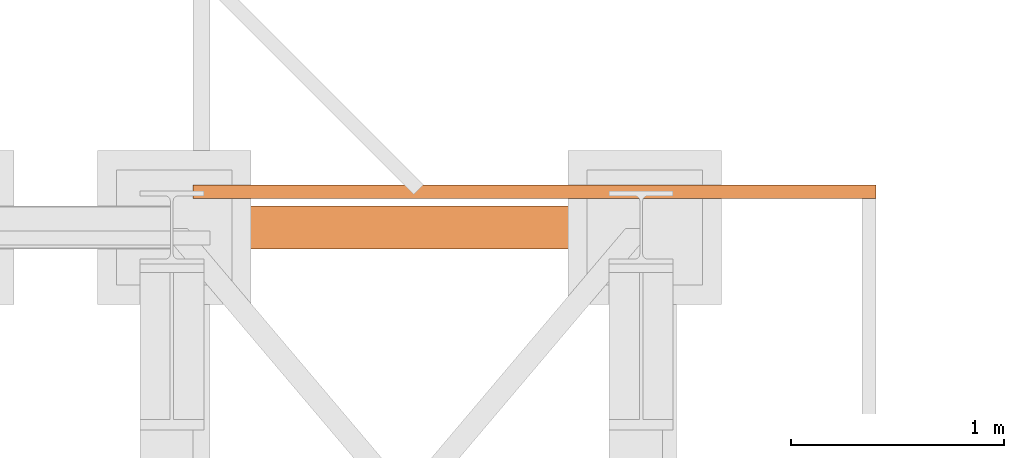
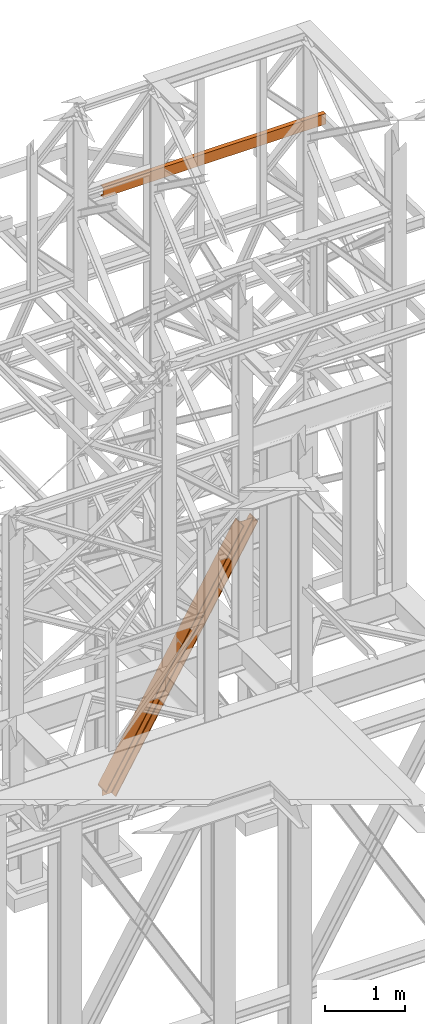
# One storey, part 199 of 208: 2 proxies.
"""IFC2X3 building model written with IfcOpenShell, lengths in millimetres."""

from ifc_helpers import new_model, entity, si_unit, converted_unit, frame, origin, origin_with_axes, place, context, subcontext, project, spatial, faceted_brep, element, save


model = new_model("IFC2X3")

# Units and contexts
model_context = context("Model", 3, precision=1e-05, world=origin())
plan_context = context("Plan", 3, precision=1e-05, world=origin())
body_context = subcontext(model_context, "Body", "Model", "MODEL_VIEW")
ifc_project = project(units=[si_unit("LENGTHUNIT", "METRE", prefix="MILLI"), converted_unit("PLANEANGLEUNIT", "DEGREE", entity("IfcPlaneAngleMeasure", 0.0174532925199433), si_unit("PLANEANGLEUNIT", "RADIAN"), dimensions=[0, 0, 0, 0, 0, 0, 0]), si_unit("AREAUNIT", "SQUARE_METRE"), si_unit("VOLUMEUNIT", "CUBIC_METRE")], contexts=[model_context, plan_context])

# Building, storey
building_placement = place(None, origin())
building = spatial("IfcBuilding", under=ifc_project, at=building_placement, CompositionType="COMPLEX")
storey_placement = place(building_placement, origin_with_axes())
storey = spatial("IfcBuildingStorey", under=building, at=storey_placement, Name="Geschoss", CompositionType="ELEMENT")

# Proxies
proxy_1_placement = place(storey_placement, frame((6599.25488355921, -12562.57439501764, 734.9900149335328), z_axis=(0.0, 0.0, 1.0), x_axis=(1.0, 0.0, 0.0)))
element("IfcBuildingElementProxy", 1, at=proxy_1_placement, inside=storey, context=body_context, shape_type="Brep", body=[
    faceted_brep([(0.01008502161312208, 0.01000000000021828, 120.8497915510924), (0.01008502161312208, 200.0100029802325, 120.8497915510924), (1970.595410063093, 200.0100029802325, 3468.009977913908), (1970.595410063093, 0.01000000000021828, 3468.009977913908), (0.01008502161312208, 200.0100029802325, 120.8497915510924), (0.01008502161312208, 200.0100029802325, 101.4682129393398), (1982.007890767009, 200.0100029802325, 3468.009977913908), (1970.595410063093, 200.0100029802325, 3468.009977913908), (0.01008502161312208, 200.0100029802325, 101.4682129393398), (0.01008502127388056, 121.2600035762789, 101.4681984983711), (1982.007899269971, 121.2600035762789, 3468.009977913908), (1982.007890767009, 200.0100029802325, 3468.009977913908), (0.01008502127388056, 121.2600035762789, 101.4681984983711), (0.009999999999308784, 111.9441915473344, 97.85427409430258), (1984.135808151257, 111.9441915473344, 3468.009977913909), (1982.007899269971, 121.2600035762789, 3468.009977913908), (0.009999999999308784, 111.9441915473344, 97.85427409430258), (0.01008502161312208, 105.1245498640838, 84.63689245399041), (1991.918714280975, 105.1245498640838, 3468.009977913908), (1984.135808151257, 111.9441915473344, 3468.009977913909), (0.01008502161312208, 105.1245498640838, 84.63689245399041), (0.01008502161312208, 103.2600015571716, 66.58142866151923), (2002.550367938204, 103.2600015571716, 3468.009977913908), (1991.918714280975, 105.1245498640838, 3468.009977913908), (0.01008502161312208, 103.2600015571716, 0.009999999999990905), (113.7187158034394, 103.2600015571716, 0.01000000000021828), (2155.477653586077, 103.2600015571716, 3468.009977913908), (2002.550367938204, 103.2600015571716, 3468.009977913908), (0.01008502161312208, 103.2600015571716, 66.58142866151923), (113.7187158034394, 103.2600015571716, 0.01000000000021828), (124.3486060538462, 105.1245498640838, 0.01000000000010459), (2166.109307243305, 105.1245498640838, 3468.009977913908), (2155.477653586077, 103.2600015571716, 3468.009977913908), (124.3486060538462, 105.1245498640838, 0.01000000000010459), (132.1302232850376, 111.9441915473344, 0.009999999999763531), (2173.892213373023, 111.9441915473344, 3468.009977913908), (2166.109307243305, 105.1245498640838, 3468.009977913908), (132.1302232850376, 111.9441915473344, 0.009999999999763531), (134.2577800655363, 121.2600035762789, 0.009999999999763531), (2176.020122254309, 121.2600035762789, 3468.009977913907), (2173.892213373023, 111.9441915473344, 3468.009977913908), (134.2577800655363, 121.2600035762789, 0.009999999999763531), (134.2577800655363, 200.0100029802325, 0.009999999999763531), (2176.020122254309, 200.0100029802325, 3468.009977913907), (2176.020122254309, 121.2600035762789, 3468.009977913907), (134.2577800655363, 200.0100029802325, 0.009999999999763531), (145.6683745225655, 200.0100029802325, 0.009999999999990905), (2187.432602958224, 200.0100029802325, 3468.009977913908), (2176.020122254309, 200.0100029802325, 3468.009977913907), (145.6683745225655, 200.0100029802325, 0.009999999999990905), (145.6683745225655, 0.01000000000021828, 0.009999999999990905), (2187.432602958224, 0.01000000000021828, 3468.009977913908), (2187.432602958224, 200.0100029802325, 3468.009977913908), (145.6683745225655, 0.01000000000021828, 0.009999999999990905), (134.2577800655363, 0.01000000000021828, 0.009999999999877218), (2176.020122254307, 0.01000000000021828, 3468.009977913908), (2187.432602958224, 0.01000000000021828, 3468.009977913908), (134.2577800655363, 0.01000000000021828, 0.009999999999877218), (134.2577800655363, 78.75999940395377, 0.009999999999763531), (2176.020122254309, 78.75999940395377, 3468.009977913907), (2176.020122254307, 0.01000000000021828, 3468.009977913908), (134.2577800655363, 78.75999940395377, 0.009999999999763531), (132.1302232850376, 88.07581143289826, 0.009999999999763531), (2173.892213373023, 88.07581143290008, 3468.009977913908), (2176.020122254309, 78.75999940395377, 3468.009977913907), (132.1302232850376, 88.07581143289826, 0.009999999999763531), (124.3486060538453, 94.89545311614893, 0.009999999999763531), (2166.109307243305, 94.89545311614893, 3468.009977913908), (2173.892213373023, 88.07581143290008, 3468.009977913908), (124.3486060538453, 94.89545311614893, 0.009999999999763531), (113.7187158034394, 96.76000142306111, 0.01000000000021828), (2155.477653586077, 96.76000142306111, 3468.009977913908), (2166.109307243305, 94.89545311614893, 3468.009977913908), (113.7187158034394, 96.76000142306111, 0.01000000000021828), (0.01008502161312208, 96.76000142306111, 0.009999999999990905), (0.01008502161312208, 96.76000142306111, 66.58142866151888), (2002.550367938204, 96.76000142306111, 3468.009977913908), (2155.477653586077, 96.76000142306111, 3468.009977913908), (0.01008502161312208, 96.76000142306111, 66.58142866151888), (0.01008502161312208, 94.89545311615075, 84.63689245399041), (1991.918714280975, 94.89545311614893, 3468.009977913908), (2002.550367938204, 96.76000142306111, 3468.009977913908), (0.01008502161312208, 94.89545311615075, 84.63689245399041), (0.01008502161312208, 88.07581143289826, 97.85441850857092), (1984.135808151257, 88.07581143289826, 3468.009977913909), (1991.918714280975, 94.89545311614893, 3468.009977913908), (0.01008502161312208, 88.07581143289826, 97.85441850857092), (0.01016988588980894, 78.75999940395377, 101.4683426459951), (1982.007899269971, 78.75999940395377, 3468.009977913908), (1984.135808151257, 88.07581143289826, 3468.009977913909), (0.01016988588980894, 78.75999940395377, 101.4683426459951), (0.0100850219523636, 0.01000000000021828, 101.4682129399164), (1982.007890767009, 0.01000000000021828, 3468.009977913908), (1982.007899269971, 78.75999940395377, 3468.009977913908), (0.0100850219523636, 0.01000000000021828, 101.4682129399164), (0.01008502161312208, 0.01000000000021828, 120.8497915510924), (1970.595410063093, 0.01000000000021828, 3468.009977913908), (1982.007890767009, 0.01000000000021828, 3468.009977913908), (1970.595410063093, 0.01000000000021828, 3468.009977913908), (1970.595410063093, 200.0100029802325, 3468.009977913908), (1982.007890767009, 200.0100029802325, 3468.009977913908), (1982.007899269971, 121.2600035762789, 3468.009977913908), (1984.135808151257, 111.9441915473344, 3468.009977913909), (1991.918714280975, 105.1245498640838, 3468.009977913908), (2002.550367938204, 103.2600015571716, 3468.009977913908), (2155.477653586077, 103.2600015571716, 3468.009977913908), (2166.109307243305, 105.1245498640838, 3468.009977913908), (2173.892213373023, 111.9441915473344, 3468.009977913908), (2176.020122254309, 121.2600035762789, 3468.009977913907), (2176.020122254309, 200.0100029802325, 3468.009977913907), (2187.432602958224, 200.0100029802325, 3468.009977913908), (2187.432602958224, 0.01000000000021828, 3468.009977913908), (2176.020122254307, 0.01000000000021828, 3468.009977913908), (2176.020122254309, 78.75999940395377, 3468.009977913907), (2173.892213373023, 88.07581143290008, 3468.009977913908), (2166.109307243305, 94.89545311614893, 3468.009977913908), (2155.477653586077, 96.76000142306111, 3468.009977913908), (2002.550367938204, 96.76000142306111, 3468.009977913908), (1991.918714280975, 94.89545311614893, 3468.009977913908), (1984.135808151257, 88.07581143289826, 3468.009977913909), (1982.007899269971, 78.75999940395377, 3468.009977913908), (1982.007890767009, 0.01000000000021828, 3468.009977913908), (0.01008502161312208, 96.76000142306111, 0.009999999999990905), (0.01008502161312208, 103.2600015571716, 0.009999999999990905), (0.01008502161312208, 103.2600015571716, 66.58142866151923), (0.01008502161312208, 105.1245498640838, 84.63689245399041), (0.009999999999308784, 111.9441915473344, 97.85427409430258), (0.01008502127388056, 121.2600035762789, 101.4681984983711), (0.01008502161312208, 200.0100029802325, 101.4682129393398), (0.01008502161312208, 200.0100029802325, 120.8497915510924), (0.01008502161312208, 0.01000000000021828, 120.8497915510924), (0.0100850219523636, 0.01000000000021828, 101.4682129399164), (0.01016988588980894, 78.75999940395377, 101.4683426459951), (0.01008502161312208, 88.07581143289826, 97.85441850857092), (0.01008502161312208, 94.89545311615075, 84.63689245399041), (0.01008502161312208, 96.76000142306111, 66.58142866151888), (113.7187158034394, 103.2600015571716, 0.01000000000021828), (0.01008502161312208, 103.2600015571716, 0.009999999999990905), (0.01008502161312208, 96.76000142306111, 0.009999999999990905), (113.7187158034394, 96.76000142306111, 0.01000000000021828), (124.3486060538453, 94.89545311614893, 0.009999999999763531), (132.1302232850376, 88.07581143289826, 0.009999999999763531), (134.2577800655363, 78.75999940395377, 0.009999999999763531), (134.2577800655363, 0.01000000000021828, 0.009999999999877218), (145.6683745225655, 0.01000000000021828, 0.009999999999990905), (145.6683745225655, 200.0100029802325, 0.009999999999990905), (134.2577800655363, 200.0100029802325, 0.009999999999763531), (134.2577800655363, 121.2600035762789, 0.009999999999763531), (132.1302232850376, 111.9441915473344, 0.009999999999763531), (124.3486060538462, 105.1245498640838, 0.01000000000010459)], [[[0, 1, 2, 3]], [[4, 5, 6, 7]], [[8, 9, 10, 11]], [[12, 13, 14, 15]], [[16, 17, 18, 19]], [[20, 21, 22, 23]], [[24, 25, 26, 27, 28]], [[29, 30, 31, 32]], [[33, 34, 35, 36]], [[37, 38, 39, 40]], [[41, 42, 43, 44]], [[45, 46, 47, 48]], [[49, 50, 51, 52]], [[53, 54, 55, 56]], [[57, 58, 59, 60]], [[61, 62, 63, 64]], [[65, 66, 67, 68]], [[69, 70, 71, 72]], [[73, 74, 75, 76, 77]], [[78, 79, 80, 81]], [[82, 83, 84, 85]], [[86, 87, 88, 89]], [[90, 91, 92, 93]], [[94, 95, 96, 97]], [[98, 99, 100, 101, 102, 103, 104, 105, 106, 107, 108, 109, 110, 111, 112, 113, 114, 115, 116, 117, 118, 119, 120, 121]], [[122, 123, 124, 125, 126, 127, 128, 129, 130, 131, 132, 133, 134, 135]], [[136, 137, 138, 139, 140, 141, 142, 143, 144, 145, 146, 147, 148, 149]]], orient=[[False], [False], [False], [False], [False], [False], [False], [False], [False], [False], [False], [False], [False], [False], [False], [False], [False], [False], [False], [False], [False], [False], [False], [False], [False], [False], [False]]),
])
proxy_2_placement = place(storey_placement, frame((6693.254970018783, -12327.3316522506, 9699.99), z_axis=(0.0, 0.0, 1.0), x_axis=(1.0, 0.0, 0.0)))
element("IfcBuildingElementProxy", 2, at=proxy_2_placement, inside=storey, context=body_context, shape_type="Brep", body=[
    faceted_brep([(0.009999999999308784, 65.01000000000022, 0.01000000000021828), (3199.767263422828, 65.01000000000022, 0.01000000000021828), (3199.767263422828, 65.01000000000022, 3.132428070246533), (0.009999999999308784, 65.01000000000022, 3.132428070246533), (0.009999999999308784, 65.01000000000022, 3.132428070246533), (3199.767263422828, 65.01000000000022, 3.132428070246533), (3199.767263422828, 64.76726342282564, 4.748288908171162), (0.009999999999308784, 64.76726342282564, 4.748288908171162), (0.009999999999308784, 64.76726342282564, 4.748288908171162), (3199.767263422828, 64.76726342282564, 4.748288908171162), (3199.767263422828, 64.06053228585733, 6.221534443444398), (0.009999999999308784, 64.06053228585733, 6.221534443444398), (0.009999999999308784, 64.06053228585733, 6.221534443444398), (3199.767263422828, 64.06053228585733, 6.221534443444398), (3199.767263422828, 62.95215163846842, 7.422126703873801), (0.009999999999308784, 62.95215163847024, 7.422126703873801), (0.009999999999308784, 62.95215163847024, 7.422126703873801), (3199.767263422828, 62.95215163846842, 7.422126703873801), (3199.767263422828, 61.53995641148504, 8.244091391710754), (0.009999999999308784, 61.53995641148504, 8.244091391710754), (0.009999999999308784, 61.53995641148504, 8.244091391710754), (3199.767263422828, 61.53995641148504, 8.244091391710754), (3199.767263422828, 59.9485987225562, 8.614912102195376), (0.009999999999308784, 59.9485987225562, 8.614912102195376), (0.009999999999308784, 59.9485987225562, 8.614912102195376), (3199.767263422828, 59.9485987225562, 8.614912102195376), (3199.767263422828, 17.17267516602988, 12.0369859867169), (0.009999999999308784, 17.17267516602988, 12.0369859867169), (0.009999999999308784, 17.17267516602988, 12.0369859867169), (3199.767263422828, 17.17267516602988, 12.0369859867169), (3199.767263422828, 14.13462866898408, 12.74491643400506), (0.009999999999308784, 14.13462866898408, 12.74491643400506), (0.009999999999308784, 14.13462866898408, 12.74491643400506), (3199.767263422828, 14.13462866898408, 12.74491643400506), (3199.767263422828, 11.43861959928654, 14.31412174714933), (0.009999999999308784, 11.43861959928654, 14.31412174714933), (0.009999999999308784, 11.43861959928654, 14.31412174714933), (3199.767263422828, 11.43861959928654, 14.31412174714933), (3199.767263422828, 9.322620181546881, 16.60616151705835), (0.009999999999308784, 9.322620181546881, 16.60616151705835), (0.009999999999308784, 9.322620181546881, 16.60616151705835), (3199.767263422828, 9.322620181546881, 16.60616151705835), (3199.767263422828, 7.973406192784751, 19.41872117530875), (0.009999999999308784, 7.973406192784751, 19.41872117530875), (0.009999999999308784, 7.973406192784751, 19.41872117530875), (3199.767263422828, 7.973406192784751, 19.41872117530875), (3199.767263422828, 7.510000000000218, 22.50354641134618), (0.009999999999308784, 7.510000000000218, 22.50354641134618), (0.009999999999308784, 7.510000000000218, 22.50354641134618), (3199.767263422828, 7.510000000000218, 22.50354641134618), (3199.767263422828, 7.510000000000218, 137.5164535886524), (0.009999999999308784, 7.510000000000218, 137.5164535886524), (0.009999999999308784, 7.510000000000218, 137.5164535886524), (3199.767263422828, 7.510000000000218, 137.5164535886524), (3199.767263422828, 7.973406192784751, 140.6012788246917), (0.009999999999308784, 7.973406192784751, 140.6012788246917), (0.009999999999308784, 7.973406192784751, 140.6012788246917), (3199.767263422828, 7.973406192784751, 140.6012788246917), (3199.767263422828, 9.322620181546881, 143.4138384829403), (0.009999999999308784, 9.322620181546881, 143.4138384829403), (0.009999999999308784, 9.322620181546881, 143.4138384829403), (3199.767263422828, 9.322620181546881, 143.4138384829403), (3199.767263422828, 11.43861959928654, 145.7058782528493), (0.009999999999308784, 11.43861959928654, 145.7058782528493), (0.009999999999308784, 11.43861959928654, 145.7058782528493), (3199.767263422828, 11.43861959928654, 145.7058782528493), (3199.767263422828, 14.13462866898408, 147.2750835659936), (0.009999999999308784, 14.13462866898408, 147.2750835659936), (0.009999999999308784, 14.13462866898408, 147.2750835659936), (3199.767263422828, 14.13462866898408, 147.2750835659936), (3199.767263422828, 17.17267516602988, 147.9830140132817), (0.009999999999308784, 17.17267516602988, 147.9830140132817), (0.009999999999308784, 17.17267516602988, 147.9830140132817), (3199.767263422828, 17.17267516602988, 147.9830140132817), (3199.767263422828, 59.9485987225562, 151.4050878978032), (0.009999999999308784, 59.9485987225562, 151.4050878978032), (0.009999999999308784, 59.9485987225562, 151.4050878978032), (3199.767263422828, 59.9485987225562, 151.4050878978032), (3199.767263422828, 61.53995641148504, 151.7759086082879), (0.009999999999308784, 61.53995641148504, 151.7759086082879), (0.009999999999308784, 61.53995641148504, 151.7759086082879), (3199.767263422828, 61.53995641148504, 151.7759086082879), (3199.767263422828, 62.95215163846842, 152.5978732961248), (0.009999999999308784, 62.95215163847024, 152.5978732961248), (0.009999999999308784, 62.95215163847024, 152.5978732961248), (3199.767263422828, 62.95215163846842, 152.5978732961248), (3199.767263422828, 64.06053228585733, 153.7984655565542), (0.009999999999308784, 64.06053228585733, 153.7984655565542), (0.009999999999308784, 64.06053228585733, 153.7984655565542), (3199.767263422828, 64.06053228585733, 153.7984655565542), (3199.767263422828, 64.76726342282564, 155.2717110918275), (0.009999999999308784, 64.76726342282564, 155.2717110918275), (0.009999999999308784, 64.76726342282564, 155.2717110918275), (3199.767263422828, 64.76726342282564, 155.2717110918275), (3199.767263422828, 65.01000000000022, 156.8875719297521), (0.009999999999308784, 65.01000000000022, 156.8875719297521), (0.009999999999308784, 65.01000000000022, 156.8875719297521), (3199.767263422828, 65.01000000000022, 156.8875719297521), (3199.767263422828, 65.01000000000022, 160.0100000000002), (0.009999999999308784, 65.01000000000022, 160.0100000000002), (0.009999999999308784, 65.01000000000022, 160.0100000000002), (3199.767263422828, 65.01000000000022, 160.0100000000002), (3199.767263422828, 0.01000000000021828, 160.0100000000002), (0.009999999999308784, 0.01000000000021828, 160.0100000000002), (0.009999999999308784, 0.01000000000021828, 160.0100000000002), (3199.767263422828, 0.01000000000021828, 160.0100000000002), (3199.767263422828, 0.01000000000021828, 0.01000000000021828), (0.009999999999308784, 0.01000000000021828, 0.01000000000021828), (0.009999999999308784, 0.01000000000021828, 0.01000000000021828), (3199.767263422828, 0.01000000000021828, 0.01000000000021828), (3199.767263422828, 65.01000000000022, 0.01000000000021828), (0.009999999999308784, 65.01000000000022, 0.01000000000021828), (0.009999999999308784, 65.01000000000022, 0.01000000000021828), (0.009999999999308784, 65.01000000000022, 3.132428070246533), (0.009999999999308784, 64.76726342282564, 4.748288908171162), (0.009999999999308784, 64.06053228585733, 6.221534443444398), (0.009999999999308784, 62.95215163847024, 7.422126703873801), (0.009999999999308784, 61.53995641148504, 8.244091391710754), (0.009999999999308784, 59.9485987225562, 8.614912102195376), (0.009999999999308784, 17.17267516602988, 12.0369859867169), (0.009999999999308784, 14.13462866898408, 12.74491643400506), (0.009999999999308784, 11.43861959928654, 14.31412174714933), (0.009999999999308784, 9.322620181546881, 16.60616151705835), (0.009999999999308784, 7.973406192784751, 19.41872117530875), (0.009999999999308784, 7.510000000000218, 22.50354641134618), (0.009999999999308784, 7.510000000000218, 137.5164535886524), (0.009999999999308784, 7.973406192784751, 140.6012788246917), (0.009999999999308784, 9.322620181546881, 143.4138384829403), (0.009999999999308784, 11.43861959928654, 145.7058782528493), (0.009999999999308784, 14.13462866898408, 147.2750835659936), (0.009999999999308784, 17.17267516602988, 147.9830140132817), (0.009999999999308784, 59.9485987225562, 151.4050878978032), (0.009999999999308784, 61.53995641148504, 151.7759086082879), (0.009999999999308784, 62.95215163847024, 152.5978732961248), (0.009999999999308784, 64.06053228585733, 153.7984655565542), (0.009999999999308784, 64.76726342282564, 155.2717110918275), (0.009999999999308784, 65.01000000000022, 156.8875719297521), (0.009999999999308784, 65.01000000000022, 160.0100000000002), (0.009999999999308784, 0.01000000000021828, 160.0100000000002), (0.009999999999308784, 0.01000000000021828, 0.01000000000021828), (3199.767263422828, 65.01000000000022, 0.01000000000021828), (3199.767263422828, 0.01000000000021828, 0.01000000000021828), (3199.767263422828, 0.01000000000021828, 160.0100000000002), (3199.767263422828, 65.01000000000022, 160.0100000000002), (3199.767263422828, 65.01000000000022, 156.8875719297521), (3199.767263422828, 64.76726342282564, 155.2717110918275), (3199.767263422828, 64.06053228585733, 153.7984655565542), (3199.767263422828, 62.95215163846842, 152.5978732961248), (3199.767263422828, 61.53995641148504, 151.7759086082879), (3199.767263422828, 59.9485987225562, 151.4050878978032), (3199.767263422828, 17.17267516602988, 147.9830140132817), (3199.767263422828, 14.13462866898408, 147.2750835659936), (3199.767263422828, 11.43861959928654, 145.7058782528493), (3199.767263422828, 9.322620181546881, 143.4138384829403), (3199.767263422828, 7.973406192784751, 140.6012788246917), (3199.767263422828, 7.510000000000218, 137.5164535886524), (3199.767263422828, 7.510000000000218, 22.50354641134618), (3199.767263422828, 7.973406192784751, 19.41872117530875), (3199.767263422828, 9.322620181546881, 16.60616151705835), (3199.767263422828, 11.43861959928654, 14.31412174714933), (3199.767263422828, 14.13462866898408, 12.74491643400506), (3199.767263422828, 17.17267516602988, 12.0369859867169), (3199.767263422828, 59.9485987225562, 8.614912102195376), (3199.767263422828, 61.53995641148504, 8.244091391710754), (3199.767263422828, 62.95215163846842, 7.422126703873801), (3199.767263422828, 64.06053228585733, 6.221534443444398), (3199.767263422828, 64.76726342282564, 4.748288908171162), (3199.767263422828, 65.01000000000022, 3.132428070246533)], [[[0, 1, 2, 3]], [[4, 5, 6, 7]], [[8, 9, 10, 11]], [[12, 13, 14, 15]], [[16, 17, 18, 19]], [[20, 21, 22, 23]], [[24, 25, 26, 27]], [[28, 29, 30, 31]], [[32, 33, 34, 35]], [[36, 37, 38, 39]], [[40, 41, 42, 43]], [[44, 45, 46, 47]], [[48, 49, 50, 51]], [[52, 53, 54, 55]], [[56, 57, 58, 59]], [[60, 61, 62, 63]], [[64, 65, 66, 67]], [[68, 69, 70, 71]], [[72, 73, 74, 75]], [[76, 77, 78, 79]], [[80, 81, 82, 83]], [[84, 85, 86, 87]], [[88, 89, 90, 91]], [[92, 93, 94, 95]], [[96, 97, 98, 99]], [[100, 101, 102, 103]], [[104, 105, 106, 107]], [[108, 109, 110, 111]], [[112, 113, 114, 115, 116, 117, 118, 119, 120, 121, 122, 123, 124, 125, 126, 127, 128, 129, 130, 131, 132, 133, 134, 135, 136, 137, 138, 139]], [[140, 141, 142, 143, 144, 145, 146, 147, 148, 149, 150, 151, 152, 153, 154, 155, 156, 157, 158, 159, 160, 161, 162, 163, 164, 165, 166, 167]]], orient=[[False], [False], [False], [False], [False], [False], [False], [False], [False], [False], [False], [False], [False], [False], [False], [False], [False], [False], [False], [False], [False], [False], [False], [False], [False], [False], [False], [False], [False], [False]]),
])

save(model, "model.ifc")
